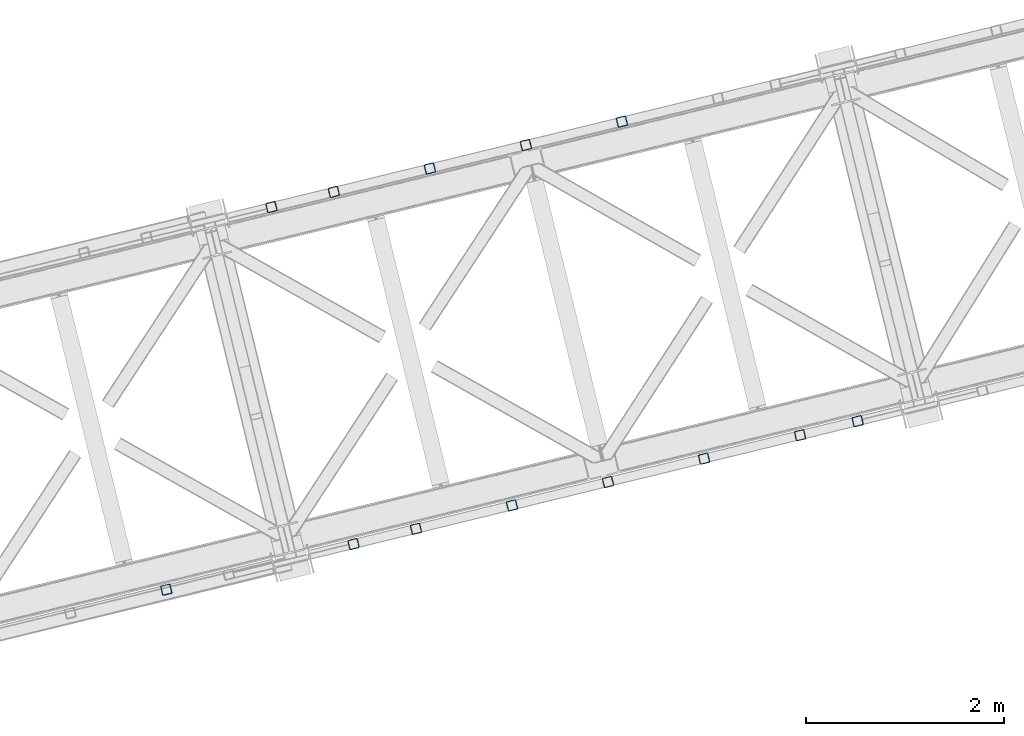
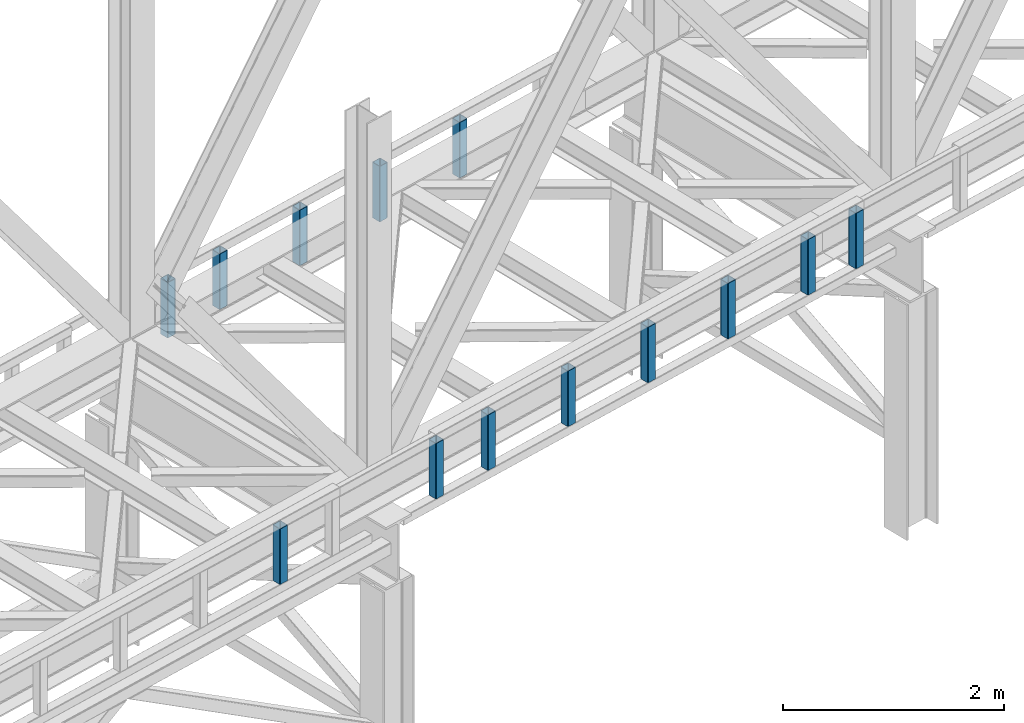
# One storey, part 8 of 92: 13 columns.
"""IFC4 building model written with IfcOpenShell, lengths in millimetres."""

from ifc_helpers import new_model, entity, si_unit, converted_unit, derived_unit, direction, frame, origin, place, context, subcontext, project, spatial, indexed_curve, outline, extrude, type_object, element, save


model = new_model("IFC4")

# Units and contexts
model_context = context("Model", 3, precision=0.01, world=origin(), true_north=direction((6.12303176911189e-17, 1.0)))
plan_context = context("Plan", 3, precision=0.01, world=origin(), true_north=direction((6.12303176911189e-17, 1.0)))
body_context = subcontext(model_context, "Body", "Model", "MODEL_VIEW")
ifc_project = project(units=[si_unit("LENGTHUNIT", "METRE", prefix="MILLI"), si_unit("AREAUNIT", "SQUARE_METRE"), si_unit("VOLUMEUNIT", "CUBIC_METRE"), converted_unit("PLANEANGLEUNIT", "DEGREE", entity("IfcRatioMeasure", 0.0174532925199433), si_unit("PLANEANGLEUNIT", "RADIAN"), dimensions=[0, 0, 0, 0, 0, 0, 0]), si_unit("MASSUNIT", "GRAM", prefix="KILO"), derived_unit("MASSDENSITYUNIT", [(si_unit("MASSUNIT", "GRAM", prefix="KILO"), 1), (si_unit("LENGTHUNIT", "METRE"), -3)]), derived_unit("MOMENTOFINERTIAUNIT", [(si_unit("LENGTHUNIT", "METRE"), 4)]), si_unit("TIMEUNIT", "SECOND"), si_unit("FREQUENCYUNIT", "HERTZ"), si_unit("THERMODYNAMICTEMPERATUREUNIT", "DEGREE_CELSIUS"), derived_unit("THERMALTRANSMITTANCEUNIT", [(si_unit("MASSUNIT", "GRAM", prefix="KILO"), 1), (si_unit("THERMODYNAMICTEMPERATUREUNIT", "KELVIN"), -1), (si_unit("TIMEUNIT", "SECOND"), -3)]), derived_unit("VOLUMETRICFLOWRATEUNIT", [(si_unit("LENGTHUNIT", "METRE"), 3), (si_unit("TIMEUNIT", "SECOND"), -1)]), derived_unit("MASSFLOWRATEUNIT", [(si_unit("MASSUNIT", "GRAM", prefix="KILO"), 1), (si_unit("TIMEUNIT", "SECOND"), -1)]), derived_unit("ROTATIONALFREQUENCYUNIT", [(si_unit("TIMEUNIT", "SECOND"), -1)]), si_unit("ELECTRICCURRENTUNIT", "AMPERE"), si_unit("ELECTRICVOLTAGEUNIT", "VOLT"), si_unit("POWERUNIT", "WATT"), si_unit("FORCEUNIT", "NEWTON", prefix="KILO"), si_unit("ILLUMINANCEUNIT", "LUX"), si_unit("LUMINOUSFLUXUNIT", "LUMEN"), si_unit("LUMINOUSINTENSITYUNIT", "CANDELA"), derived_unit("USERDEFINED", [(si_unit("MASSUNIT", "GRAM", prefix="KILO"), -1), (si_unit("LENGTHUNIT", "METRE"), -2), (si_unit("TIMEUNIT", "SECOND"), 3), (si_unit("LUMINOUSFLUXUNIT", "LUMEN"), 1)]), derived_unit("LINEARVELOCITYUNIT", [(si_unit("LENGTHUNIT", "METRE"), 1), (si_unit("TIMEUNIT", "SECOND"), -1)]), si_unit("PRESSUREUNIT", "PASCAL"), derived_unit("USERDEFINED", [(si_unit("LENGTHUNIT", "METRE"), -2), (si_unit("MASSUNIT", "GRAM", prefix="KILO"), 1), (si_unit("TIMEUNIT", "SECOND"), -2)]), derived_unit("LINEARFORCEUNIT", [(si_unit("MASSUNIT", "GRAM", prefix="KILO"), 1), (si_unit("LENGTHUNIT", "METRE"), 1), (si_unit("TIMEUNIT", "SECOND"), -2), (si_unit("LENGTHUNIT", "METRE"), -1)]), derived_unit("PLANARFORCEUNIT", [(si_unit("MASSUNIT", "GRAM", prefix="KILO"), 1), (si_unit("LENGTHUNIT", "METRE"), 1), (si_unit("TIMEUNIT", "SECOND"), -2), (si_unit("LENGTHUNIT", "METRE"), -2)])], contexts=[model_context, plan_context])

# Site, building, storey
site_placement = place(None, origin())
site = spatial("IfcSite", under=ifc_project, at=site_placement, CompositionType="ELEMENT")
building_placement = place(site_placement, origin())
building = spatial("IfcBuilding", under=site, at=building_placement, CompositionType="ELEMENT")
storey_placement = place(building_placement, frame((0.0, 0.0, 15900.0)))
storey = spatial("IfcBuildingStorey", under=building, at=storey_placement, Name="05", CompositionType="ELEMENT", Elevation=15900.0)

# Columns
column_type_1 = type_object("IfcColumnType", PredefinedType="COLUMN")
placement = place(storey_placement, origin())
element("IfcColumn", 1, at=placement, inside=storey, type_object=column_type_1, ObjectType="Steel Column", PredefinedType="COLUMN", context=body_context, shape_type="SweptSolid", body=[
    extrude(outline(indexed_curve([(29.4768951153002, -56.8428769008257), (33.3787015556201, -56.8428769008257), (36.9835006656566, -55.3497202198225), (39.742494458495, -52.5907264269942), (41.2356511394973, -48.9859273169575), (56.8428769008221, 29.4768951152923), (56.8428769008298, 33.3787015556134), (55.349720219815, 36.9835006656505), (52.5907264269858, 39.7424944584821), (48.9859273169559, 41.2356511394885), (-29.476895115292, 56.8428769008124), (-33.3787015556159, 56.8428769008142), (-36.9835006656493, 55.3497202198072), (-39.7424944584781, 52.5907264269792), (-41.2356511394882, 48.9859273169462), (-56.8428769008091, -29.4768951153055), (-56.8428769008129, -33.3787015556285), (-55.3497202198068, -36.9835006656639), (-52.5907264269816, -39.7424944584937), (-48.9859273169477, -41.2356511395019), (29.4768951153002, -56.8428769008257)], self_intersect=False), holes=[indexed_curve([(-43.1065493048536, -37.3071763475669), (-46.7113484148787, -35.8140196665604), (-49.4703422077127, -33.0550258737289), (-50.9634988887139, -29.4502267636934), (-50.9634988887149, -25.5484203233706), (-37.3071763475512, 43.1065493048462), (-35.8140196665489, 46.7113484148829), (-33.0550258737144, 49.4703422077131), (-29.4502267636828, 50.9634988887161), (-25.5484203233628, 50.9634988887161), (43.1065493048635, 37.3071763475575), (46.7113484148926, 35.8140196665492), (49.4703422077244, 33.0550258737234), (50.9634988887278, 29.4502267636822), (50.9634988887297, 25.5484203233613), (37.307176347576, -43.1065493048649), (35.8140196665589, -46.7113484148923), (33.0550258737274, -49.4703422077263), (29.4502267636918, -50.9634988887275), (25.5484203233728, -50.9634988887255), (-43.1065493048536, -37.3071763475669)], self_intersect=False)]), frame((-32396.38, 13101.24, 3168.0), z_axis=(0.0, 0.0, 1.0), x_axis=(0.906681479027134, 0.421815949898968, 0.0)), (0.0, 0.0, 1.0), 612.000000000008),
])
column_type_2 = type_object("IfcColumnType", PredefinedType="COLUMN")
element("IfcColumn", 2, at=placement, inside=storey, type_object=column_type_2, ObjectType="Steel Column", PredefinedType="COLUMN", context=body_context, shape_type="SweptSolid", body=[
    extrude(outline(indexed_curve([(29.4768951153325, -56.8428769008098), (33.3787015556564, -56.8428769008098), (36.9835006656882, -55.3497202198031), (39.7424944585157, -52.5907264269738), (41.2356511395251, -48.9859273169381), (56.8428769008131, 29.476895115319), (56.8428769008112, 33.3787015556438), (55.3497202198034, 36.9835006656785), (52.5907264269769, 39.742494458507), (48.9859273169423, 41.2356511395135), (-29.4768951153177, 56.8428769008006), (-33.3787015556416, 56.8428769008006), (-36.9835006656783, 55.3497202197937), (-39.7424944585018, 52.5907264269625), (-41.2356511395103, 48.9859273169289), (-56.8428769007944, -29.4768951153301), (-56.8428769007964, -33.3787015556531), (-55.3497202197934, -36.9835006656879), (-52.5907264269621, -39.7424944585163), (-48.9859273169275, -41.2356511395228), (29.4768951153325, -56.8428769008098)], self_intersect=False), holes=[indexed_curve([(-43.1065493048312, -37.3071763475869), (-46.711348414861, -35.8140196665803), (-49.4703422076905, -33.055025873748), (-50.9634988886943, -29.4502267637151), (-50.9634988886981, -25.5484203233943), (-37.3071763475696, 43.1065493048327), (-35.8140196665699, 46.7113484148681), (-33.0550258737433, 49.4703422076955), (-29.4502267637009, 50.9634988887044), (-25.5484203233819, 50.9634988887043), (43.1065493048509, 37.3071763475778), (46.7113484148816, 35.8140196665731), (49.470342207712, 33.0550258737428), (50.9634988887197, 29.4502267637081), (50.9634988887226, 25.5484203233853), (37.307176347594, -43.1065493048417), (35.8140196665886, -46.7113484148792), (33.055025873759, -49.4703422077028), (29.4502267637205, -50.9634988887136), (25.5484203233976, -50.9634988887116), (-43.1065493048312, -37.3071763475869)], self_intersect=False)]), frame((-33367.94, 12864.42, 3168.0), z_axis=(0.0, 0.0, 1.0), x_axis=(0.906681479027331, 0.421815949898544, 0.0)), (0.0, 0.0, 1.0), 612.000000000008),
])
column_type_3 = type_object("IfcColumnType", PredefinedType="COLUMN")
element("IfcColumn", 3, at=placement, inside=storey, type_object=column_type_3, ObjectType="Steel Column", PredefinedType="COLUMN", context=body_context, shape_type="SweptSolid", body=[
    extrude(outline(indexed_curve([(29.4768951153208, -56.8428769008043), (33.3787015556446, -56.8428769008043), (36.9835006656813, -55.3497202197975), (39.7424944585048, -52.5907264269663), (41.2356511395172, -48.9859273169345), (56.8428769008022, 29.4768951153265), (56.8428769007994, 33.3787015556493), (55.3497202197955, 36.9835006656822), (52.5907264269651, 39.7424944585125), (48.9859273169305, 41.235651139519), (-29.4768951153295, 56.842876900806), (-33.3787015556495, 56.8428769008042), (-36.98350066569, 55.3497202197992), (-39.7424944585175, 52.5907264269698), (-41.235651139522, 48.9859273169343), (-56.8428769008062, -29.4768951153247), (-56.8428769008121, -33.3787015556458), (-55.3497202198052, -36.9835006656825), (-52.5907264269739, -39.7424944585108), (-48.9859273169393, -41.2356511395173), (29.4768951153208, -56.8428769008043)], self_intersect=False), holes=[indexed_curve([(-43.1065493048439, -37.3071763475834), (-46.7113484148737, -35.8140196665768), (-49.4703422077071, -33.0550258737427), (-50.9634988887167, -29.4502267637119), (-50.9634988887148, -25.5484203233889), (-37.3071763475862, 43.106549304838), (-35.8140196665807, 46.7113484148755), (-33.055025873756, 49.470342207699), (-29.4502267637127, 50.9634988887099), (-25.5484203233946, 50.9634988887078), (43.1065493048343, 37.3071763475832), (46.711348414864, 35.8140196665765), (49.4703422076944, 33.0550258737462), (50.963498888707, 29.4502267637116), (50.963498888706, 25.5484203233906), (37.3071763475813, -43.1065493048382), (35.814019666572, -46.7113484148738), (33.0550258737415, -49.4703422076994), (29.4502267637039, -50.9634988887082), (25.5484203233849, -50.9634988887081), (-43.1065493048439, -37.3071763475834)], self_intersect=False)]), frame((-34339.49, 12627.59, 3168.0), z_axis=(0.0, 0.0, 1.0), x_axis=(0.906681479027331, 0.421815949898544, 0.0)), (0.0, 0.0, 1.0), 612.000000000008),
])
column_type_4 = type_object("IfcColumnType", PredefinedType="COLUMN")
element("IfcColumn", 4, at=placement, inside=storey, type_object=column_type_4, ObjectType="Steel Column", PredefinedType="COLUMN", context=body_context, shape_type="SweptSolid", body=[
    extrude(outline(indexed_curve([(29.4768951153029, -56.8428769008198), (33.3787015556228, -56.8428769008198), (36.9835006656593, -55.3497202198166), (39.7424944584929, -52.5907264269884), (41.2356511394991, -48.9859273169536), (56.84287690082, 29.4768951152981), (56.8428769008277, 33.3787015556192), (55.3497202198177, 36.9835006656564), (52.5907264269886, 39.742494458488), (48.9859273169586, 41.2356511394944), (-29.4768951152941, 56.8428769008181), (-33.3787015556141, 56.8428769008181), (-36.9835006656514, 55.349720219813), (-39.7424944584841, 52.5907264269867), (-41.2356511394904, 48.9859273169519), (-56.8428769008112, -29.4768951152998), (-56.8428769008189, -33.3787015556209), (-55.3497202198089, -36.9835006656581), (-52.5907264269837, -39.7424944584879), (-48.9859273169498, -41.2356511394961), (29.4768951153029, -56.8428769008198)], self_intersect=False), holes=[indexed_curve([(-43.1065493048517, -37.307176347563), (-46.711348414876, -35.8140196665545), (-49.470342207706, -33.0550258737249), (-50.9634988887111, -29.4502267636875), (-50.9634988887131, -25.5484203233666), (-37.3071763475524, 43.106549304854), (-35.8140196665471, 46.7113484148868), (-33.0550258737126, 49.470342207717), (-29.4502267636801, 50.963498888722), (-25.5484203233601, 50.963498888722), (43.1065493048644, 37.3071763475595), (46.7113484148983, 35.8140196665513), (49.4703422077293, 33.0550258737236), (50.9634988887296, 29.4502267636861), (50.9634988887316, 25.5484203233652), (37.3071763475669, -43.1065493048535), (35.8140196665655, -46.7113484148882), (33.0550258737322, -49.4703422077261), (29.4502267636985, -50.9634988887234), (25.5484203233707, -50.9634988887198), (-43.1065493048517, -37.307176347563)], self_intersect=False)]), frame((-35311.04, 12390.76, 3168.0), z_axis=(0.0, 0.0, 1.0), x_axis=(0.906681479027134, 0.421815949898968, 0.0)), (0.0, 0.0, 1.0), 612.000000000008),
])
column_type_5 = type_object("IfcColumnType", PredefinedType="COLUMN")
element("IfcColumn", 5, at=placement, inside=storey, type_object=column_type_5, ObjectType="Steel Column", PredefinedType="COLUMN", context=body_context, shape_type="SweptSolid", body=[
    extrude(outline(indexed_curve([(29.4768951153286, -56.842876900808), (33.3787015556525, -56.842876900808), (36.9835006656843, -55.3497202198013), (39.7424944585166, -52.5907264269718), (41.2356511395211, -48.9859273169363), (56.8428769008092, 29.4768951153209), (56.8428769008112, 33.3787015556438), (55.3497202197995, 36.9835006656803), (52.590726426973, 39.7424944585088), (48.9859273169384, 41.2356511395154), (-29.4768951153217, 56.8428769008024), (-33.3787015556455, 56.8428769008024), (-36.9835006656783, 55.3497202197937), (-39.7424944585097, 52.5907264269662), (-41.2356511395142, 48.9859273169307), (-56.8428769007983, -29.4768951153283), (-56.8428769008042, -33.3787015556494), (-55.3497202197925, -36.983500665686), (-52.590726426966, -39.7424944585145), (-48.9859273169314, -41.235651139521), (29.4768951153286, -56.842876900808)], self_intersect=False), holes=[indexed_curve([(-43.1065493048352, -37.3071763475851), (-46.7113484148659, -35.8140196665804), (-49.4703422076993, -33.0550258737463), (-50.9634988887031, -29.4502267637134), (-50.963498888706, -25.5484203233906), (-37.3071763475783, 43.1065493048344), (-35.8140196665738, 46.7113484148699), (-33.0550258737415, 49.4703422076994), (-29.4502267637048, 50.9634988887063), (-25.5484203233858, 50.9634988887061), (43.106549304843, 37.3071763475815), (46.7113484148719, 35.8140196665728), (49.4703422077062, 33.0550258737407), (50.9634988887149, 29.450226763708), (50.9634988887178, 25.5484203233851), (37.3071763475901, -43.1065493048399), (35.8140196665847, -46.7113484148774), (33.0550258737493, -49.4703422077031), (29.4502267637127, -50.9634988887099), (25.5484203233937, -50.9634988887098), (-43.1065493048352, -37.3071763475851)], self_intersect=False)]), frame((-35942.55, 12236.83, 3168.0), z_axis=(0.0, 0.0, 1.0), x_axis=(0.906681479027331, 0.421815949898544, 0.0)), (0.0, 0.0, 1.0), 612.000000000008),
])
column_type_6 = type_object("IfcColumnType", PredefinedType="COLUMN")
element("IfcColumn", 6, at=placement, inside=storey, type_object=column_type_6, ObjectType="Steel Column", PredefinedType="COLUMN", context=body_context, shape_type="SweptSolid", body=[
    extrude(outline(indexed_curve([(29.476895115299, -56.842876900818), (33.3787015556189, -56.842876900818), (36.9835006656514, -55.349720219813), (39.7424944584811, -52.590726426983), (41.2356511394913, -48.98592731695), (56.842876900817, 29.4768951153019), (56.8428769008159, 33.3787015556247), (55.3497202198098, 36.9835006656601), (52.5907264269847, 39.7424944584899), (48.9859273169547, 41.2356511394962), (-29.476895115302, 56.8428769008218), (-33.3787015556259, 56.8428769008236), (-36.9835006656544, 55.3497202198168), (-39.742494458492, 52.5907264269904), (-41.2356511394982, 48.9859273169556), (-56.8428769008191, -29.4768951152961), (-56.8428769008268, -33.3787015556172), (-55.3497202198129, -36.9835006656563), (-52.5907264269916, -39.7424944584843), (-48.9859273169577, -41.2356511394924), (29.476895115299, -56.842876900818)], self_intersect=False), holes=[indexed_curve([(-43.1065493048557, -37.3071763475612), (-46.7113484148896, -35.814019666553), (-49.4703422077205, -33.0550258737253), (-50.9634988887296, -29.4502267636861), (-50.9634988887258, -25.5484203233631), (-37.3071763475739, 43.1065493048592), (-35.814019666554, 46.7113484148924), (-33.0550258737234, 49.4703422077244), (-29.4502267636879, 50.9634988887257), (-25.548420323365, 50.9634988887219), (43.1065493048487, 37.3071763475668), (46.7113484148817, 35.8140196665566), (49.4703422077166, 33.0550258737271), (50.9634988887178, 29.4502267636916), (50.9634988887189, 25.5484203233687), (37.3071763475621, -43.1065493048537), (35.814019666551, -46.7113484148886), (33.0550258737144, -49.4703422077131), (29.450226763681, -50.96349888872), (25.5484203233619, -50.9634988887181), (-43.1065493048557, -37.3071763475612)], self_intersect=False)]), frame((-30010.88, 10070.99, 3168.0), z_axis=(0.0, 0.0, 1.0), x_axis=(-0.906681479027134, -0.421815949898968, 0.0)), (0.0, 0.0, 1.0), 612.000000000008),
])
column_type_7 = type_object("IfcColumnType", PredefinedType="COLUMN")
element("IfcColumn", 7, at=placement, inside=storey, type_object=column_type_7, ObjectType="Steel Column", PredefinedType="COLUMN", context=body_context, shape_type="SweptSolid", body=[
    extrude(outline(indexed_curve([(29.4768951153029, -56.8428769008198), (33.3787015556228, -56.8428769008198), (36.9835006656554, -55.3497202198148), (39.742494458485, -52.5907264269848), (41.2356511394952, -48.9859273169518), (56.8428769008209, 29.4768951153), (56.8428769008198, 33.3787015556228), (55.3497202198138, 36.9835006656582), (52.5907264269886, 39.742494458488), (48.9859273169586, 41.2356511394944), (-29.4768951152981, 56.84287690082), (-33.3787015556219, 56.8428769008218), (-36.9835006656505, 55.349720219815), (-39.742494458488, 52.5907264269886), (-41.2356511394943, 48.9859273169538), (-56.8428769008151, -29.4768951152979), (-56.8428769008229, -33.3787015556191), (-55.3497202198089, -36.9835006656581), (-52.5907264269877, -39.7424944584861), (-48.9859273169538, -41.2356511394943), (29.4768951153029, -56.8428769008198)], self_intersect=False), holes=[indexed_curve([(-43.1065493048508, -37.307176347561), (-46.7113484148896, -35.814019666553), (-49.4703422077205, -33.0550258737253), (-50.9634988887248, -29.4502267636859), (-50.9634988887258, -25.5484203233631), (-37.307176347569, 43.1065493048593), (-35.814019666554, 46.7113484148924), (-33.0550258737234, 49.4703422077244), (-29.4502267636831, 50.9634988887258), (-25.5484203233601, 50.963498888722), (43.1065493048536, 37.3071763475669), (46.7113484148856, 35.8140196665548), (49.4703422077166, 33.0550258737271), (50.9634988887178, 29.4502267636916), (50.9634988887189, 25.5484203233687), (37.307176347563, -43.1065493048517), (35.814019666551, -46.7113484148886), (33.0550258737192, -49.4703422077129), (29.4502267636858, -50.9634988887199), (25.5484203233668, -50.9634988887179), (-43.1065493048508, -37.307176347561)], self_intersect=False)]), frame((-30593.81, 9928.89, 3168.0), z_axis=(0.0, 0.0, 1.0), x_axis=(-0.906681479027134, -0.421815949898968, 0.0)), (0.0, 0.0, 1.0), 612.000000000008),
])
column_type_8 = type_object("IfcColumnType", PredefinedType="COLUMN")
element("IfcColumn", 8, at=placement, inside=storey, type_object=column_type_8, ObjectType="Steel Column", PredefinedType="COLUMN", context=body_context, shape_type="SweptSolid", body=[
    extrude(outline(indexed_curve([(29.4768951153128, -56.8428769008116), (33.3787015556323, -56.8428769008116), (36.9835006656693, -55.3497202198055), (39.7424944584973, -52.5907264269767), (41.2356511395066, -48.9859273169434), (56.8428769008086, 29.4768951153142), (56.842876900811, 33.3787015556362), (55.349720219804, 36.9835006656712), (52.5907264269781, 39.7424944585003), (48.9859273169438, 41.2356511395076), (-29.4768951153084, 56.8428769008107), (-33.3787015556279, 56.8428769008107), (-36.9835006656644, 55.3497202198056), (-39.7424944585017, 52.5907264269776), (-41.2356511395066, 48.9859273169434), (-56.8428769008082, -29.4768951153132), (-56.8428769008149, -33.3787015556344), (-55.3497202197996, -36.983500665672), (-52.5907264269733, -39.7424944585002), (-48.9859273169395, -41.2356511395084), (29.4768951153128, -56.8428769008116)], self_intersect=False), holes=[indexed_curve([(-43.1065493048467, -37.307176347573), (-46.711348414881, -35.8140196665657), (-49.4703422077087, -33.0550258737405), (-50.9634988887134, -29.4502267637006), (-50.9634988887159, -25.5484203233788), (-37.3071763475803, 43.1065493048489), (-35.8140196665637, 46.7113484148777), (-33.0550258737329, 49.4703422077123), (-29.4502267637021, 50.9634988887153), (-25.5484203233782, 50.9634988887145), (43.1065493048467, 37.307176347573), (46.7113484148792, 35.8140196665618), (49.4703422077113, 33.0550258737358), (50.9634988887134, 29.4502267637006), (50.963498888715, 25.5484203233768), (37.307176347569, -43.1065493048425), (35.8140196665676, -46.7113484148795), (33.0550258737294, -49.4703422077095), (29.4502267637026, -50.9634988887143), (25.5484203233826, -50.9634988887153), (-43.1065493048467, -37.307176347573)], self_intersect=False)]), frame((-31565.36, 9692.07, 3168.0), z_axis=(0.0, 0.0, 1.0), x_axis=(-0.90668147902724, -0.42181594989874, 0.0)), (0.0, 0.0, 1.0), 612.000000000008),
])
column_type_9 = type_object("IfcColumnType", PredefinedType="COLUMN")
element("IfcColumn", 9, at=placement, inside=storey, type_object=column_type_9, ObjectType="Steel Column", PredefinedType="COLUMN", context=body_context, shape_type="SweptSolid", body=[
    extrude(outline(indexed_curve([(29.4768951153119, -56.8428769008135), (33.3787015556314, -56.8428769008135), (36.9835006656728, -55.3497202198083), (39.7424944584964, -52.5907264269787), (41.2356511395061, -48.9859273169443), (56.8428769008077, 29.4768951153122), (56.8428769008101, 33.3787015556342), (55.3497202198075, 36.9835006656684), (52.5907264269772, 39.7424944584983), (48.9859273169429, 41.2356511395056), (-29.4768951153133, 56.8428769008106), (-33.3787015556376, 56.8428769008104), (-36.9835006656697, 55.3497202198045), (-39.7424944584983, 52.5907264269748), (-41.2356511395119, 48.9859273169422), (-56.8428769008135, -29.4768951153144), (-56.8428769008114, -33.3787015556372), (-55.3497202198049, -36.9835006656732), (-52.590726426979, -39.7424944585023), (-48.9859273169443, -41.2356511395086), (29.4768951153119, -56.8428769008135)], self_intersect=False), holes=[indexed_curve([(-43.1065493048476, -37.307176347575), (-46.7113484148863, -35.8140196665668), (-49.4703422077122, -33.0550258737377), (-50.9634988887192, -29.4502267637027), (-50.9634988887207, -25.5484203233789), (-37.3071763475778, 43.1065493048442), (-35.814019666572, 46.7113484148803), (-33.0550258737404, 49.4703422077063), (-29.4502267637069, 50.9634988887152), (-25.5484203233791, 50.9634988887125), (43.1065493048419, 37.3071763475729), (46.7113484148752, 35.8140196665636), (49.4703422077046, 33.0550258737317), (50.9634988887077, 29.4502267636985), (50.9634988887101, 25.5484203233767), (37.3071763475672, -43.1065493048464), (35.8140196665667, -46.7113484148814), (33.0550258737356, -49.4703422077064), (29.4502267636973, -50.9634988887154), (25.5484203233773, -50.9634988887164), (-43.1065493048476, -37.307176347575)], self_intersect=False)]), frame((-32536.91, 9455.24, 3168.0), z_axis=(0.0, 0.0, 1.0), x_axis=(-0.90668147902724, -0.42181594989874, 0.0)), (0.0, 0.0, 1.0), 612.000000000008),
])
column_type_10 = type_object("IfcColumnType", PredefinedType="COLUMN")
element("IfcColumn", 10, at=placement, inside=storey, type_object=column_type_10, ObjectType="Steel Column", PredefinedType="COLUMN", context=body_context, shape_type="SweptSolid", body=[
    extrude(outline(indexed_curve([(29.4768951153089, -56.8428769008097), (33.3787015556284, -56.8428769008097), (36.9835006656693, -55.3497202198055), (39.7424944584978, -52.5907264269757), (41.2356511395027, -48.9859273169415), (56.8428769008042, 29.4768951153151), (56.842876900811, 33.3787015556362), (55.3497202198045, 36.9835006656722), (52.5907264269698, 39.742494458503), (48.9859273169399, 41.2356511395094), (-29.4768951153167, 56.8428769008134), (-33.3787015556406, 56.8428769008142), (-36.9835006656771, 55.3497202198091), (-39.7424944585013, 52.5907264269785), (-41.2356511395149, 48.985927316946), (-56.8428769008165, -29.4768951153106), (-56.8428769008149, -33.3787015556344), (-55.3497202198123, -36.9835006656685), (-52.590726426986, -39.7424944584967), (-48.9859273169478, -41.2356511395058), (29.4768951153089, -56.8428769008097)], self_intersect=False), holes=[indexed_curve([(-43.1065493048506, -37.3071763475712), (-46.7113484148849, -35.8140196665639), (-49.4703422077113, -33.0550258737358), (-50.9634988887222, -29.4502267636989), (-50.9634988887198, -25.548420323377), (-37.3071763475808, 43.1065493048479), (-35.8140196665711, 46.7113484148823), (-33.0550258737395, 49.4703422077082), (-29.450226763706, 50.9634988887171), (-25.5484203233822, 50.9634988887163), (43.1065493048379, 37.3071763475747), (46.7113484148727, 35.8140196665684), (49.4703422077055, 33.0550258737337), (50.9634988887143, 29.4502267637026), (50.9634988887111, 25.5484203233787), (37.3071763475681, -43.1065493048444), (35.8140196665623, -46.7113484148806), (33.0550258737326, -49.4703422077026), (29.4502267636933, -50.9634988887136), (25.5484203233743, -50.9634988887126), (-43.1065493048506, -37.3071763475712)], self_intersect=False)]), frame((-33508.47, 9218.41, 3168.0), z_axis=(0.0, 0.0, 1.0), x_axis=(-0.90668147902724, -0.42181594989874, 0.0)), (0.0, 0.0, 1.0), 612.000000000008),
])
column_type_11 = type_object("IfcColumnType", PredefinedType="COLUMN")
element("IfcColumn", 11, at=placement, inside=storey, type_object=column_type_11, ObjectType="Steel Column", PredefinedType="COLUMN", context=body_context, shape_type="SweptSolid", body=[
    extrude(outline(indexed_curve([(29.4768951153128, -56.8428769008116), (33.3787015556323, -56.8428769008116), (36.9835006656693, -55.3497202198055), (39.7424944585017, -52.5907264269776), (41.2356511395066, -48.9859273169434), (56.8428769008086, 29.4768951153142), (56.8428769008149, 33.3787015556344), (55.349720219804, 36.9835006656712), (52.5907264269737, 39.7424944585011), (48.9859273169438, 41.2356511395076), (-29.4768951153128, 56.8428769008116), (-33.3787015556323, 56.8428769008116), (-36.9835006656688, 55.3497202198065), (-39.7424944585017, 52.5907264269776), (-41.2356511395066, 48.9859273169434), (-56.8428769008082, -29.4768951153132), (-56.8428769008149, -33.3787015556344), (-55.349720219804, -36.9835006656712), (-52.5907264269776, -39.7424944584993), (-48.9859273169438, -41.2356511395076), (29.4768951153128, -56.8428769008116)], self_intersect=False), holes=[indexed_curve([(-43.1065493048467, -37.307176347573), (-46.7113484148884, -35.8140196665611), (-49.4703422077161, -33.0550258737359), (-50.9634988887173, -29.4502267636988), (-50.9634988887194, -25.548420323376), (-37.3071763475729, 43.1065493048443), (-35.814019666572, 46.7113484148803), (-33.0550258737403, 49.470342207717), (-29.45022676371, 50.963498888719), (-25.5484203233778, 50.9634988887154), (43.1065493048423, 37.3071763475738), (46.7113484148757, 35.8140196665646), (49.470342207703, 33.0550258737384), (50.9634988887095, 29.4502267637024), (50.9634988887115, 25.5484203233796), (37.3071763475685, -43.1065493048435), (35.8140196665641, -46.7113484148767), (33.0550258737259, -49.4703422077067), (29.4502267636982, -50.9634988887135), (25.5484203233782, -50.9634988887145), (-43.1065493048467, -37.307176347573)], self_intersect=False)]), frame((-34480.02, 8981.59, 3168.0), z_axis=(0.0, 0.0, 1.0), x_axis=(-0.90668147902724, -0.42181594989874, 0.0)), (0.0, 0.0, 1.0), 612.000000000008),
])
column_type_12 = type_object("IfcColumnType", PredefinedType="COLUMN")
element("IfcColumn", 12, at=placement, inside=storey, type_object=column_type_12, ObjectType="Steel Column", PredefinedType="COLUMN", context=body_context, shape_type="SweptSolid", body=[
    extrude(outline(indexed_curve([(29.476895115305, -56.8428769008079), (33.3787015556245, -56.8428769008079), (36.9835006656614, -55.3497202198019), (39.7424944584939, -52.5907264269739), (41.2356511394987, -48.9859273169397), (56.8428769008008, 29.4768951153179), (56.8428769008075, 33.378701555639), (55.3497202197961, 36.9835006656748), (52.5907264269703, 39.7424944585039), (48.985927316936, 41.2356511395112), (-29.4768951153207, 56.8428769008152), (-33.3787015556446, 56.8428769008161), (-36.9835006656767, 55.3497202198101), (-39.7424944585096, 52.5907264269812), (-41.2356511395188, 48.9859273169479), (-56.8428769008204, -29.4768951153087), (-56.8428769008228, -33.3787015556307), (-55.3497202198119, -36.9835006656675), (-52.590726426986, -39.7424944584966), (-48.9859273169512, -41.2356511395029), (29.476895115305, -56.8428769008079)], self_intersect=False), holes=[indexed_curve([(-43.1065493048546, -37.3071763475693), (-46.7113484148879, -35.8140196665601), (-49.4703422077182, -33.0550258737301), (-50.9634988887256, -29.4502267636961), (-50.9634988887268, -25.5484203233713), (-37.3071763475847, 43.1065493048498), (-35.8140196665789, 46.711348414886), (-33.0550258737421, 49.470342207713), (-29.45022676371, 50.963498888719), (-25.5484203233861, 50.9634988887181), (43.1065493048349, 37.3071763475785), (46.7113484148697, 35.8140196665722), (49.470342207702, 33.0550258737365), (50.963498888706, 29.4502267637052), (50.9634988887071, 25.5484203233805), (37.3071763475651, -43.1065493048406), (35.8140196665606, -46.7113484148739), (33.0550258737225, -49.4703422077039), (29.4502267636903, -50.9634988887098), (25.5484203233704, -50.9634988887108), (-43.1065493048546, -37.3071763475693)], self_intersect=False)]), frame((-35111.53, 8827.65, 3168.0), z_axis=(0.0, 0.0, 1.0), x_axis=(-0.90668147902724, -0.42181594989874, 0.0)), (0.0, 0.0, 1.0), 612.000000000008),
])
column_type_13 = type_object("IfcColumnType", PredefinedType="COLUMN")
element("IfcColumn", 13, at=placement, inside=storey, type_object=column_type_13, ObjectType="Steel Column", PredefinedType="COLUMN", context=body_context, shape_type="SweptSolid", body=[
    extrude(outline(indexed_curve([(29.4768951153133, -56.8428769008106), (33.3787015556328, -56.8428769008106), (36.9835006656737, -55.3497202198063), (39.7424944584978, -52.5907264269757), (41.235651139507, -48.9859273169424), (56.8428769008086, 29.4768951153142), (56.842876900811, 33.3787015556362), (55.3497202198088, 36.9835006656714), (52.5907264269742, 39.7424944585022), (48.9859273169443, 41.2356511395086), (-29.4768951153124, 56.8428769008125), (-33.3787015556319, 56.8428769008125), (-36.9835006656688, 55.3497202198065), (-39.7424944584969, 52.5907264269777), (-41.2356511395105, 48.9859273169452), (-56.8428769008121, -29.4768951153114), (-56.8428769008105, -33.3787015556352), (-55.3497202198035, -36.9835006656702), (-52.5907264269776, -39.7424944584993), (-48.9859273169434, -41.2356511395066), (29.4768951153133, -56.8428769008106)], self_intersect=False), holes=[indexed_curve([(-43.1065493048463, -37.307176347572), (-46.7113484148805, -35.8140196665647), (-49.4703422077055, -33.0550258737337), (-50.9634988887139, -29.4502267637016), (-50.9634988887154, -25.5484203233778), (-37.3071763475729, 43.1065493048443), (-35.8140196665628, 46.7113484148796), (-33.0550258737351, 49.4703422077074), (-29.4502267637017, 50.9634988887163), (-25.5484203233778, 50.9634988887154), (43.1065493048432, 37.3071763475758), (46.7113484148766, 35.8140196665666), (49.4703422077099, 33.0550258737328), (50.9634988887139, 29.4502267637016), (50.9634988887154, 25.5484203233778), (37.3071763475725, -43.1065493048453), (35.8140196665667, -46.7113484148814), (33.055025873737, -49.4703422077035), (29.4502267636986, -50.9634988887125), (25.5484203233787, -50.9634988887135), (-43.1065493048463, -37.307176347572)], self_intersect=False)]), frame((-37006.05, 8365.84, 3168.0), z_axis=(0.0, 0.0, 1.0), x_axis=(-0.90668147902724, -0.42181594989874, 0.0)), (0.0, 0.0, 1.0), 612.000000000008),
])

save(model, "model.ifc")
